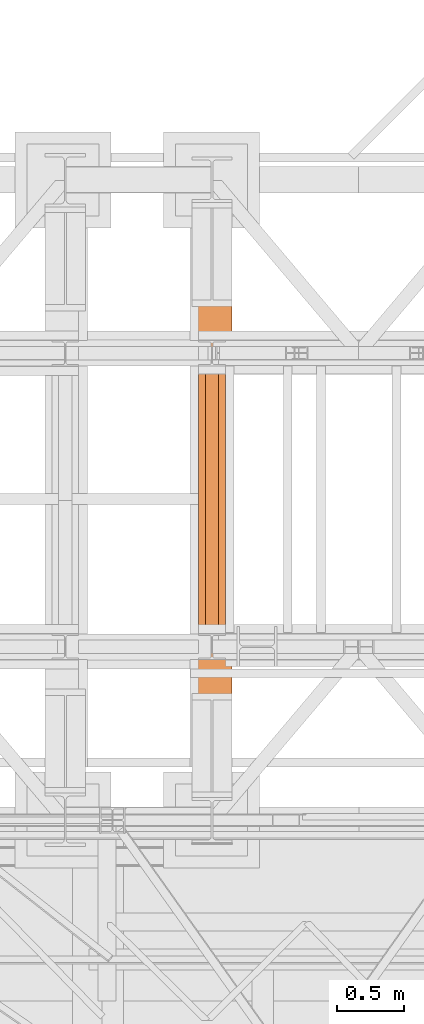
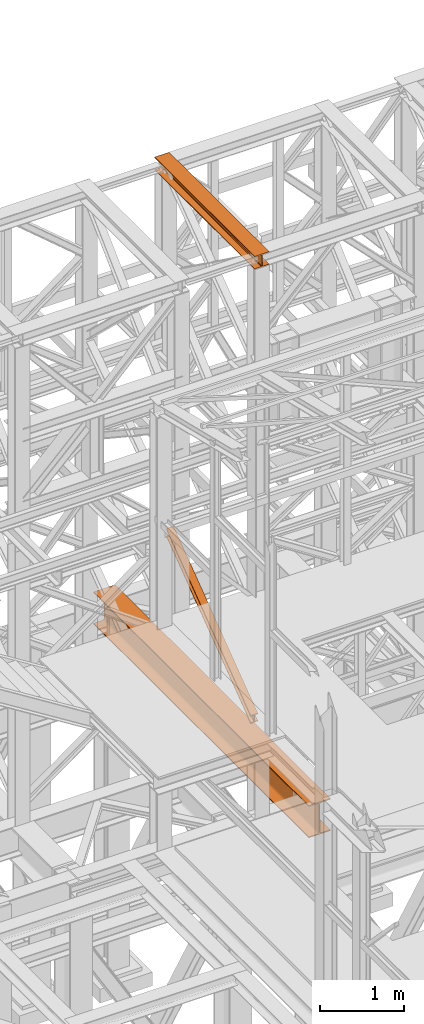
# One storey, part 124 of 208: 3 proxies.
"""IFC2X3 building model written with IfcOpenShell, lengths in millimetres."""

from ifc_helpers import new_model, entity, si_unit, converted_unit, frame, origin, origin_with_axes, place, context, subcontext, project, spatial, faceted_brep, element, save


model = new_model("IFC2X3")

# Units and contexts
model_context = context("Model", 3, precision=1e-05, world=origin())
plan_context = context("Plan", 3, precision=1e-05, world=origin())
body_context = subcontext(model_context, "Body", "Model", "MODEL_VIEW")
ifc_project = project(units=[si_unit("LENGTHUNIT", "METRE", prefix="MILLI"), converted_unit("PLANEANGLEUNIT", "DEGREE", entity("IfcPlaneAngleMeasure", 0.0174532925199433), si_unit("PLANEANGLEUNIT", "RADIAN"), dimensions=[0, 0, 0, 0, 0, 0, 0]), si_unit("AREAUNIT", "SQUARE_METRE"), si_unit("VOLUMEUNIT", "CUBIC_METRE")], contexts=[model_context, plan_context])

# Building, storey
building_placement = place(None, origin())
building = spatial("IfcBuilding", under=ifc_project, at=building_placement, CompositionType="COMPLEX")
storey_placement = place(building_placement, origin_with_axes())
storey = spatial("IfcBuildingStorey", under=building, at=storey_placement, Name="Geschoss", CompositionType="ELEMENT")

# Proxies
proxy_1_placement = place(storey_placement, frame((3143.254974489131, -17432.57439531566, 4812.990005364416), z_axis=(0.0, 0.0, 1.0), x_axis=(1.0, 0.0, 0.0)))
element("IfcBuildingElementProxy", 1, at=proxy_1_placement, inside=storey, context=body_context, shape_type="Brep", body=[
    faceted_brep([(300.0100000000002, 0.00999999999839929, 472.0100000000002), (300.0100000000002, 5140.010003576275, 472.0100000000002), (300.0100000000002, 5140.010003576275, 458.0100000000002), (300.0100000000002, 0.00999999999839929, 458.0100000000002), (300.0100000000002, 0.00999999999839929, 458.0100000000002), (300.0100000000002, 5140.010003576275, 458.0100000000002), (182.2600000000002, 5140.010003576275, 458.0100000000002), (182.2600000000002, 0.00999999999839929, 458.0100000000002), (182.2600000000002, 0.00999999999839929, 458.0100000000002), (182.2600000000002, 5140.010003576275, 458.0100000000002), (173.9165694541389, 5140.010003576275, 456.6884339422595), (173.9165694541389, 0.00999999999839929, 456.6884339422595), (173.9165694541389, 0.00999999999839929, 456.6884339422595), (173.9165694541389, 5140.010003576275, 456.6884339422595), (166.3898249342001, 5140.010003576275, 452.8534254634024), (166.3898249342001, 0.00999999999839929, 452.8534254634024), (166.3898249342001, 0.00999999999839929, 452.8534254634024), (166.3898249342001, 5140.010003576275, 452.8534254634024), (160.416574536599, 5140.010003576275, 446.8801750658013), (160.416574536599, 0.00999999999839929, 446.8801750658013), (160.416574536599, 0.00999999999839929, 446.8801750658013), (160.416574536599, 5140.010003576275, 446.8801750658013), (156.5815660577409, 5140.010003576275, 439.3534305458607), (156.5815660577409, 0.00999999999839929, 439.3534305458607), (156.5815660577409, 0.00999999999839929, 439.3534305458607), (156.5815660577409, 5140.010003576275, 439.3534305458607), (155.2600000000002, 5140.010003576275, 431.0100000000002), (155.2600000000002, 0.00999999999839929, 431.0100000000002), (155.2600000000002, 0.00999999999839929, 431.0100000000002), (155.2600000000002, 5140.010003576275, 431.0100000000002), (155.2600000000002, 5140.010003576275, 41.01000000000022), (155.2600000000002, 0.00999999999839929, 41.01000000000022), (155.2600000000002, 0.00999999999839929, 41.01000000000022), (155.2600000000002, 5140.010003576275, 41.01000000000022), (156.5815660577409, 5140.010003576275, 32.66656945413979), (156.5815660577409, 0.00999999999839929, 32.66656945413979), (156.5815660577409, 0.00999999999839929, 32.66656945413979), (156.5815660577409, 5140.010003576275, 32.66656945413979), (160.416574536599, 5140.010003576275, 25.13982493419826), (160.416574536599, 0.00999999999839929, 25.13982493419826), (160.416574536599, 0.00999999999839929, 25.13982493419826), (160.416574536599, 5140.010003576275, 25.13982493419826), (166.3898249342001, 5140.010003576275, 19.16657453659809), (166.3898249342001, 0.00999999999839929, 19.16657453659809), (166.3898249342001, 0.00999999999839929, 19.16657453659809), (166.3898249342001, 5140.010003576275, 19.16657453659809), (173.9165694541389, 5140.010003576275, 15.33156605774093), (173.9165694541389, 0.00999999999839929, 15.33156605774093), (173.9165694541389, 0.00999999999839929, 15.33156605774093), (173.9165694541389, 5140.010003576275, 15.33156605774093), (182.2600000000002, 5140.010003576275, 14.01000000000022), (182.2600000000002, 0.00999999999839929, 14.01000000000022), (182.2600000000002, 0.00999999999839929, 14.01000000000022), (182.2600000000002, 5140.010003576275, 14.01000000000022), (300.0100000000002, 5140.010003576275, 14.01000000000022), (300.0100000000002, 0.00999999999839929, 14.01000000000022), (300.0100000000002, 0.00999999999839929, 14.01000000000022), (300.0100000000002, 5140.010003576275, 14.01000000000022), (300.0100000000002, 5140.010003576275, 0.01000000000021828), (300.0100000000002, 0.00999999999839929, 0.01000000000021828), (300.0100000000002, 0.00999999999839929, 0.01000000000021828), (300.0100000000002, 5140.010003576275, 0.01000000000021828), (0.01000000000021828, 5140.010003576275, 0.01000000000021828), (0.01000000000021828, 0.00999999999839929, 0.01000000000021828), (0.01000000000021828, 0.00999999999839929, 0.01000000000021828), (0.01000000000021828, 5140.010003576275, 0.01000000000021828), (0.01000000000021828, 5140.010003576275, 14.01000000000022), (0.01000000000021828, 0.00999999999839929, 14.01000000000022), (0.01000000000021828, 0.00999999999839929, 14.01000000000022), (0.01000000000021828, 5140.010003576275, 14.01000000000022), (117.7600000000002, 5140.010003576275, 14.01000000000022), (117.7600000000002, 0.00999999999839929, 14.01000000000022), (117.7600000000002, 0.00999999999839929, 14.01000000000022), (117.7600000000002, 5140.010003576275, 14.01000000000022), (126.1034305458616, 5140.010003576275, 15.33156605774093), (126.1034305458616, 0.00999999999839929, 15.33156605774093), (126.1034305458616, 0.00999999999839929, 15.33156605774093), (126.1034305458616, 5140.010003576275, 15.33156605774093), (133.6301750658004, 5140.010003576275, 19.16657453659809), (133.6301750658004, 0.00999999999839929, 19.16657453659809), (133.6301750658004, 0.00999999999839929, 19.16657453659809), (133.6301750658004, 5140.010003576275, 19.16657453659809), (139.6034254634014, 5140.010003576275, 25.13982493419826), (139.6034254634014, 0.00999999999839929, 25.13982493419826), (139.6034254634014, 0.00999999999839929, 25.13982493419826), (139.6034254634014, 5140.010003576275, 25.13982493419826), (143.4384339422595, 5140.010003576275, 32.66656945413979), (143.4384339422595, 0.00999999999839929, 32.66656945413979), (143.4384339422595, 0.00999999999839929, 32.66656945413979), (143.4384339422595, 5140.010003576275, 32.66656945413979), (144.7600000000002, 5140.010003576275, 41.01000000000022), (144.7600000000002, 0.00999999999839929, 41.01000000000022), (144.7600000000002, 0.00999999999839929, 41.01000000000022), (144.7600000000002, 5140.010003576275, 41.01000000000022), (144.7600000000002, 5140.010003576275, 431.0100000000002), (144.7600000000002, 0.00999999999839929, 431.0100000000002), (144.7600000000002, 0.00999999999839929, 431.0100000000002), (144.7600000000002, 5140.010003576275, 431.0100000000002), (143.4384339422595, 5140.010003576275, 439.3534305458607), (143.4384339422595, 0.00999999999839929, 439.3534305458607), (143.4384339422595, 0.00999999999839929, 439.3534305458607), (143.4384339422595, 5140.010003576275, 439.3534305458607), (139.6034254634014, 5140.010003576275, 446.8801750658013), (139.6034254634014, 0.00999999999839929, 446.8801750658013), (139.6034254634014, 0.00999999999839929, 446.8801750658013), (139.6034254634014, 5140.010003576275, 446.8801750658013), (133.6301750658004, 5140.010003576275, 452.8534254634024), (133.6301750658004, 0.00999999999839929, 452.8534254634024), (133.6301750658004, 0.00999999999839929, 452.8534254634024), (133.6301750658004, 5140.010003576275, 452.8534254634024), (126.1034305458616, 5140.010003576275, 456.6884339422595), (126.1034305458616, 0.00999999999839929, 456.6884339422595), (126.1034305458616, 0.00999999999839929, 456.6884339422595), (126.1034305458616, 5140.010003576275, 456.6884339422595), (117.7600000000002, 5140.010003576275, 458.0100000000002), (117.7600000000002, 0.00999999999839929, 458.0100000000002), (117.7600000000002, 0.00999999999839929, 458.0100000000002), (117.7600000000002, 5140.010003576275, 458.0100000000002), (0.01000000000021828, 5140.010003576275, 458.0100000000002), (0.01000000000021828, 0.00999999999839929, 458.0100000000002), (0.01000000000021828, 0.00999999999839929, 458.0100000000002), (0.01000000000021828, 5140.010003576275, 458.0100000000002), (0.01000000000021828, 5140.010003576275, 472.0100000000002), (0.01000000000021828, 0.00999999999839929, 472.0100000000002), (0.01000000000021828, 0.00999999999839929, 472.0100000000002), (0.01000000000021828, 5140.010003576275, 472.0100000000002), (300.0100000000002, 5140.010003576275, 472.0100000000002), (300.0100000000002, 0.00999999999839929, 472.0100000000002), (300.0100000000002, 0.00999999999839929, 472.0100000000002), (300.0100000000002, 0.00999999999839929, 458.0100000000002), (182.2600000000002, 0.00999999999839929, 458.0100000000002), (173.9165694541389, 0.00999999999839929, 456.6884339422595), (166.3898249342001, 0.00999999999839929, 452.8534254634024), (160.416574536599, 0.00999999999839929, 446.8801750658013), (156.5815660577409, 0.00999999999839929, 439.3534305458607), (155.2600000000002, 0.00999999999839929, 431.0100000000002), (155.2600000000002, 0.00999999999839929, 41.01000000000022), (156.5815660577409, 0.00999999999839929, 32.66656945413979), (160.416574536599, 0.00999999999839929, 25.13982493419826), (166.3898249342001, 0.00999999999839929, 19.16657453659809), (173.9165694541389, 0.00999999999839929, 15.33156605774093), (182.2600000000002, 0.00999999999839929, 14.01000000000022), (300.0100000000002, 0.00999999999839929, 14.01000000000022), (300.0100000000002, 0.00999999999839929, 0.01000000000021828), (0.01000000000021828, 0.00999999999839929, 0.01000000000021828), (0.01000000000021828, 0.00999999999839929, 14.01000000000022), (117.7600000000002, 0.00999999999839929, 14.01000000000022), (126.1034305458616, 0.00999999999839929, 15.33156605774093), (133.6301750658004, 0.00999999999839929, 19.16657453659809), (139.6034254634014, 0.00999999999839929, 25.13982493419826), (143.4384339422595, 0.00999999999839929, 32.66656945413979), (144.7600000000002, 0.00999999999839929, 41.01000000000022), (144.7600000000002, 0.00999999999839929, 431.0100000000002), (143.4384339422595, 0.00999999999839929, 439.3534305458607), (139.6034254634014, 0.00999999999839929, 446.8801750658013), (133.6301750658004, 0.00999999999839929, 452.8534254634024), (126.1034305458616, 0.00999999999839929, 456.6884339422595), (117.7600000000002, 0.00999999999839929, 458.0100000000002), (0.01000000000021828, 0.00999999999839929, 458.0100000000002), (0.01000000000021828, 0.00999999999839929, 472.0100000000002), (300.0100000000002, 5140.010003576275, 472.0100000000002), (0.01000000000021828, 5140.010003576275, 472.0100000000002), (0.01000000000021828, 5140.010003576275, 458.0100000000002), (117.7600000000002, 5140.010003576275, 458.0100000000002), (126.1034305458616, 5140.010003576275, 456.6884339422595), (133.6301750658004, 5140.010003576275, 452.8534254634024), (139.6034254634014, 5140.010003576275, 446.8801750658013), (143.4384339422595, 5140.010003576275, 439.3534305458607), (144.7600000000002, 5140.010003576275, 431.0100000000002), (144.7600000000002, 5140.010003576275, 41.01000000000022), (143.4384339422595, 5140.010003576275, 32.66656945413979), (139.6034254634014, 5140.010003576275, 25.13982493419826), (133.6301750658004, 5140.010003576275, 19.16657453659809), (126.1034305458616, 5140.010003576275, 15.33156605774093), (117.7600000000002, 5140.010003576275, 14.01000000000022), (0.01000000000021828, 5140.010003576275, 14.01000000000022), (0.01000000000021828, 5140.010003576275, 0.01000000000021828), (300.0100000000002, 5140.010003576275, 0.01000000000021828), (300.0100000000002, 5140.010003576275, 14.01000000000022), (182.2600000000002, 5140.010003576275, 14.01000000000022), (173.9165694541389, 5140.010003576275, 15.33156605774093), (166.3898249342001, 5140.010003576275, 19.16657453659809), (160.416574536599, 5140.010003576275, 25.13982493419826), (156.5815660577409, 5140.010003576275, 32.66656945413979), (155.2600000000002, 5140.010003576275, 41.01000000000022), (155.2600000000002, 5140.010003576275, 431.0100000000002), (156.5815660577409, 5140.010003576275, 439.3534305458607), (160.416574536599, 5140.010003576275, 446.8801750658013), (166.3898249342001, 5140.010003576275, 452.8534254634024), (173.9165694541389, 5140.010003576275, 456.6884339422595), (182.2600000000002, 5140.010003576275, 458.0100000000002), (300.0100000000002, 5140.010003576275, 458.0100000000002)], [[[0, 1, 2, 3]], [[4, 5, 6, 7]], [[8, 9, 10, 11]], [[12, 13, 14, 15]], [[16, 17, 18, 19]], [[20, 21, 22, 23]], [[24, 25, 26, 27]], [[28, 29, 30, 31]], [[32, 33, 34, 35]], [[36, 37, 38, 39]], [[40, 41, 42, 43]], [[44, 45, 46, 47]], [[48, 49, 50, 51]], [[52, 53, 54, 55]], [[56, 57, 58, 59]], [[60, 61, 62, 63]], [[64, 65, 66, 67]], [[68, 69, 70, 71]], [[72, 73, 74, 75]], [[76, 77, 78, 79]], [[80, 81, 82, 83]], [[84, 85, 86, 87]], [[88, 89, 90, 91]], [[92, 93, 94, 95]], [[96, 97, 98, 99]], [[100, 101, 102, 103]], [[104, 105, 106, 107]], [[108, 109, 110, 111]], [[112, 113, 114, 115]], [[116, 117, 118, 119]], [[120, 121, 122, 123]], [[124, 125, 126, 127]], [[128, 129, 130, 131, 132, 133, 134, 135, 136, 137, 138, 139, 140, 141, 142, 143, 144, 145, 146, 147, 148, 149, 150, 151, 152, 153, 154, 155, 156, 157, 158, 159]], [[160, 161, 162, 163, 164, 165, 166, 167, 168, 169, 170, 171, 172, 173, 174, 175, 176, 177, 178, 179, 180, 181, 182, 183, 184, 185, 186, 187, 188, 189, 190, 191]]], orient=[[False], [False], [False], [False], [False], [False], [False], [False], [False], [False], [False], [False], [False], [False], [False], [False], [False], [False], [False], [False], [False], [False], [False], [False], [False], [False], [False], [False], [False], [False], [False], [False], [False], [False]]),
])
proxy_2_placement = place(storey_placement, frame((3193.25496703855, -16057.57439657638, 12249.99005869381), z_axis=(0.0, 0.0, 1.0), x_axis=(1.0, 0.0, 0.0)))
element("IfcBuildingElementProxy", 2, at=proxy_2_placement, inside=storey, context=body_context, shape_type="Brep", body=[
    faceted_brep([(0.01000000000021828, 2390.010012516977, 0.01000000000021828), (200.0100029802325, 2390.010012516977, 0.01000000000021828), (200.0100029802325, 2390.010012516977, 10.00999791383765), (121.2600035762789, 2390.010012516977, 10.01000536441825), (111.9441915473344, 2390.010012516977, 11.87455041170142), (105.1245498640838, 2390.010012516977, 18.69419349193595), (103.2600015571716, 2390.010012516977, 28.01000458955787), (103.2600015571716, 2390.010012516977, 162.0100153779986), (105.1245498640838, 2390.010012516977, 171.3258264756205), (111.9441915473344, 2390.010012516977, 178.145469555855), (121.2600035762789, 2390.010012516977, 180.0100146031382), (200.0100029802325, 2390.010012516977, 180.0100146031382), (200.0100029802325, 2390.010012516977, 190.0100125169756), (0.01000000000021828, 2390.010012516977, 190.0100125169756), (0.01000000000021828, 2390.010012516977, 180.0100146031382), (78.75999940395377, 2390.010012516977, 180.0100146031382), (88.07581143289826, 2390.010012516977, 178.145469555855), (94.89545311614893, 2390.010012516977, 171.3258264756205), (96.76000142306111, 2390.010012516977, 162.0100153779986), (96.76000142306111, 2390.010012516977, 28.01000458955787), (94.89545311614893, 2390.010012516977, 18.69419349193595), (88.07581143289826, 2390.010012516977, 11.87455041170142), (78.75999940395377, 2390.010012516977, 10.01000536441825), (0.01000000000021828, 2390.010012516977, 10.00999791383765), (200.0100029802325, 2390.010012516977, 0.01000000000021828), (0.01000000000021828, 2390.010012516977, 0.01000000000021828), (0.01000000000021828, 0.01000000000021828, 0.01000000000021828), (200.0100029802325, 0.01000000000021828, 0.01000000000021828), (200.0100029802325, 2390.010012516977, 10.00999791383765), (200.0100029802325, 2390.010012516977, 0.01000000000021828), (200.0100029802325, 0.01000000000021828, 0.01000000000021828), (200.0100029802325, 0.01000000000021828, 10.00999791383765), (121.2600035762789, 2390.010012516977, 10.01000536441825), (200.0100029802325, 2390.010012516977, 10.00999791383765), (200.0100029802325, 0.01000000000021828, 10.00999791383765), (121.2600035762789, 0.01000000000021828, 10.01000536441825), (111.9441915473344, 2390.010012516977, 11.87455041170142), (121.2600035762789, 2390.010012516977, 10.01000536441825), (121.2600035762789, 0.01000000000021828, 10.01000536441825), (111.9441915473344, 0.01000000000021828, 11.87455041170142), (105.1245498640838, 2390.010012516977, 18.69419349193595), (111.9441915473344, 2390.010012516977, 11.87455041170142), (111.9441915473344, 0.01000000000021828, 11.87455041170142), (105.1245498640838, 0.01000000000021828, 18.69419349193595), (103.2600015571716, 2390.010012516977, 28.01000458955787), (105.1245498640838, 2390.010012516977, 18.69419349193595), (105.1245498640838, 0.01000000000021828, 18.69419349193595), (103.2600015571716, 0.01000000000021828, 28.01000458955787), (103.2600015571716, 2390.010012516977, 162.0100153779986), (103.2600015571716, 2390.010012516977, 28.01000458955787), (103.2600015571716, 0.01000000000021828, 28.01000458955787), (103.2600015571716, 0.01000000000021828, 162.0100153779986), (105.1245498640838, 2390.010012516977, 171.3258264756205), (103.2600015571716, 2390.010012516977, 162.0100153779986), (103.2600015571716, 0.01000000000021828, 162.0100153779986), (105.1245498640838, 0.01000000000021828, 171.3258264756205), (111.9441915473344, 2390.010012516977, 178.145469555855), (105.1245498640838, 2390.010012516977, 171.3258264756205), (105.1245498640838, 0.01000000000021828, 171.3258264756205), (111.9441915473344, 0.01000000000021828, 178.145469555855), (121.2600035762789, 2390.010012516977, 180.0100146031382), (111.9441915473344, 2390.010012516977, 178.145469555855), (111.9441915473344, 0.01000000000021828, 178.145469555855), (121.2600035762789, 0.01000000000021828, 180.0100146031382), (200.0100029802325, 2390.010012516977, 180.0100146031382), (121.2600035762789, 2390.010012516977, 180.0100146031382), (121.2600035762789, 0.01000000000021828, 180.0100146031382), (200.0100029802325, 0.01000000000021828, 180.0100146031382), (200.0100029802325, 2390.010012516977, 190.0100125169756), (200.0100029802325, 2390.010012516977, 180.0100146031382), (200.0100029802325, 0.01000000000021828, 180.0100146031382), (200.0100029802325, 0.01000000000021828, 190.0100125169756), (0.01000000000021828, 2390.010012516977, 190.0100125169756), (200.0100029802325, 2390.010012516977, 190.0100125169756), (200.0100029802325, 0.01000000000021828, 190.0100125169756), (0.01000000000021828, 0.01000000000021828, 190.0100125169756), (0.01000000000021828, 2390.010012516977, 180.0100146031382), (0.01000000000021828, 2390.010012516977, 190.0100125169756), (0.01000000000021828, 0.01000000000021828, 190.0100125169756), (0.01000000000021828, 0.01000000000021828, 180.0100146031382), (78.75999940395377, 2390.010012516977, 180.0100146031382), (0.01000000000021828, 2390.010012516977, 180.0100146031382), (0.01000000000021828, 0.01000000000021828, 180.0100146031382), (78.75999940395377, 0.01000000000021828, 180.0100146031382), (88.07581143289826, 2390.010012516977, 178.145469555855), (78.75999940395377, 2390.010012516977, 180.0100146031382), (78.75999940395377, 0.01000000000021828, 180.0100146031382), (88.07581143289826, 0.01000000000021828, 178.145469555855), (94.89545311614893, 2390.010012516977, 171.3258264756205), (88.07581143289826, 2390.010012516977, 178.145469555855), (88.07581143289826, 0.01000000000021828, 178.145469555855), (94.89545311614893, 0.01000000000021828, 171.3258264756205), (96.76000142306111, 2390.010012516977, 162.0100153779986), (94.89545311614893, 2390.010012516977, 171.3258264756205), (94.89545311614893, 0.01000000000021828, 171.3258264756205), (96.76000142306111, 0.01000000000021828, 162.0100153779986), (96.76000142306111, 2390.010012516977, 28.01000458955787), (96.76000142306111, 2390.010012516977, 162.0100153779986), (96.76000142306111, 0.01000000000021828, 162.0100153779986), (96.76000142306111, 0.01000000000021828, 28.01000458955787), (94.89545311614893, 2390.010012516977, 18.69419349193595), (96.76000142306111, 2390.010012516977, 28.01000458955787), (96.76000142306111, 0.01000000000021828, 28.01000458955787), (94.89545311614893, 0.01000000000021828, 18.69419349193595), (88.07581143289826, 2390.010012516977, 11.87455041170142), (94.89545311614893, 2390.010012516977, 18.69419349193595), (94.89545311614893, 0.01000000000021828, 18.69419349193595), (88.07581143289826, 0.01000000000021828, 11.87455041170142), (78.75999940395377, 2390.010012516977, 10.01000536441825), (88.07581143289826, 2390.010012516977, 11.87455041170142), (88.07581143289826, 0.01000000000021828, 11.87455041170142), (78.75999940395377, 0.01000000000021828, 10.01000536441825), (0.01000000000021828, 2390.010012516977, 10.00999791383765), (78.75999940395377, 2390.010012516977, 10.01000536441825), (78.75999940395377, 0.01000000000021828, 10.01000536441825), (0.01000000000021828, 0.01000000000021828, 10.00999791383765), (0.01000000000021828, 2390.010012516977, 0.01000000000021828), (0.01000000000021828, 2390.010012516977, 10.00999791383765), (0.01000000000021828, 0.01000000000021828, 10.00999791383765), (0.01000000000021828, 0.01000000000021828, 0.01000000000021828), (0.01000000000021828, 0.01000000000021828, 0.01000000000021828), (0.01000000000021828, 0.01000000000021828, 10.00999791383765), (78.75999940395377, 0.01000000000021828, 10.01000536441825), (88.07581143289826, 0.01000000000021828, 11.87455041170142), (94.89545311614893, 0.01000000000021828, 18.69419349193595), (96.76000142306111, 0.01000000000021828, 28.01000458955787), (96.76000142306111, 0.01000000000021828, 162.0100153779986), (94.89545311614893, 0.01000000000021828, 171.3258264756205), (88.07581143289826, 0.01000000000021828, 178.145469555855), (78.75999940395377, 0.01000000000021828, 180.0100146031382), (0.01000000000021828, 0.01000000000021828, 180.0100146031382), (0.01000000000021828, 0.01000000000021828, 190.0100125169756), (200.0100029802325, 0.01000000000021828, 190.0100125169756), (200.0100029802325, 0.01000000000021828, 180.0100146031382), (121.2600035762789, 0.01000000000021828, 180.0100146031382), (111.9441915473344, 0.01000000000021828, 178.145469555855), (105.1245498640838, 0.01000000000021828, 171.3258264756205), (103.2600015571716, 0.01000000000021828, 162.0100153779986), (103.2600015571716, 0.01000000000021828, 28.01000458955787), (105.1245498640838, 0.01000000000021828, 18.69419349193595), (111.9441915473344, 0.01000000000021828, 11.87455041170142), (121.2600035762789, 0.01000000000021828, 10.01000536441825), (200.0100029802325, 0.01000000000021828, 10.00999791383765), (200.0100029802325, 0.01000000000021828, 0.01000000000021828)], [[[0, 1, 2, 3, 4, 5, 6, 7, 8, 9, 10, 11, 12, 13, 14, 15, 16, 17, 18, 19, 20, 21, 22, 23]], [[24, 25, 26, 27]], [[28, 29, 30, 31]], [[32, 33, 34, 35]], [[36, 37, 38, 39]], [[40, 41, 42, 43]], [[44, 45, 46, 47]], [[48, 49, 50, 51]], [[52, 53, 54, 55]], [[56, 57, 58, 59]], [[60, 61, 62, 63]], [[64, 65, 66, 67]], [[68, 69, 70, 71]], [[72, 73, 74, 75]], [[76, 77, 78, 79]], [[80, 81, 82, 83]], [[84, 85, 86, 87]], [[88, 89, 90, 91]], [[92, 93, 94, 95]], [[96, 97, 98, 99]], [[100, 101, 102, 103]], [[104, 105, 106, 107]], [[108, 109, 110, 111]], [[112, 113, 114, 115]], [[116, 117, 118, 119]], [[120, 121, 122, 123, 124, 125, 126, 127, 128, 129, 130, 131, 132, 133, 134, 135, 136, 137, 138, 139, 140, 141, 142, 143]]], orient=[[False], [False], [False], [False], [False], [False], [False], [False], [False], [False], [False], [False], [False], [False], [False], [False], [False], [False], [False], [False], [False], [False], [False], [False], [False], [False]]),
])
proxy_3_placement = place(storey_placement, frame((3243.082798491103, -15873.1965123697, 5499.689768811883), z_axis=(0.0, 0.0, 1.0), x_axis=(1.0, 0.0, 0.0)))
element("IfcBuildingElementProxy", 3, at=proxy_3_placement, inside=storey, context=body_context, shape_type="Brep", body=[
    faceted_brep([(100.0229428112289, 2015.632115793322, 1505.703241650141), (100.1858455764686, 1.953628280809426, 0.02100513656296243), (100.1847800613887, 1.791659257409265, 9.702984703128095), (100.0218641931642, 2015.632115793322, 1515.50632986583), (0.02294341679771605, 2015.632115793322, 1505.692236513578), (0.1858461820338562, 1.953628280809426, 0.01000000000021828), (100.1858455764686, 1.953628280809426, 0.02100513656296243), (100.0229428112289, 2015.632115793322, 1505.703241650141), (0.02186479873125791, 2015.632115793322, 1515.495324729271), (0.1847806669538841, 1.791659257407446, 9.691979566568989), (0.1858461820338562, 1.953628280809426, 0.01000000000021828), (0.02294341679771605, 2015.632115793322, 1505.692236513578), (47.52186451108355, 2015.632115793322, 1515.500552169136), (47.68478037930981, 1.791659257407446, 9.697207006434837), (0.1847806669538841, 1.791659257407446, 9.691979566568989), (0.02186479873125791, 2015.632115793322, 1515.495324729271), (47.51107833042624, 2015.632115793322, 1613.531434326045), (47.67412522851737, 0.1719690234003792, 106.517002672068), (47.68478037930981, 1.791659257407446, 9.697207006434837), (47.52186451108355, 2015.632115793322, 1515.500552169136), (0.01107861806849542, 2015.632115793322, 1613.526206886179), (0.174125516157801, 0.1719690234003792, 106.5117752322021), (47.67412522851737, 0.1719690234003792, 106.517002672068), (47.51107833042624, 2015.632115793322, 1613.531434326045), (0.01000000000021828, 2015.632115793322, 1623.329295101868), (0.1730600010778289, 0.01000000000021828, 116.1937547987636), (0.174125516157801, 0.1719690234003792, 106.5117752322021), (0.01107861806849542, 2015.632115793322, 1613.526206886179), (100.0099993944386, 2015.632115793322, 1623.340300238435), (100.1730593955126, 0.01000000000203727, 116.2047599353264), (0.1730600010778289, 0.01000000000021828, 116.1937547987636), (0.01000000000021828, 2015.632115793322, 1623.329295101868), (100.0110780125051, 2015.632115793322, 1613.537212022739), (100.1741249105908, 0.1719690234003792, 106.5227803687612), (100.1730593955126, 0.01000000000203727, 116.2047599353264), (100.0099993944386, 2015.632115793322, 1623.340300238435), (52.51107830014917, 2015.632115793322, 1613.531984582873), (52.67412519823665, 0.1719690234003792, 106.5175529288954), (100.1741249105908, 0.1719690234003792, 106.5227803687612), (100.0110780125051, 2015.632115793322, 1613.537212022739), (52.52186448080829, 2015.632115793322, 1515.501102425964), (52.68478034903274, 1.791659257409265, 9.697757263262247), (52.67412519823665, 0.1719690234003792, 106.5175529288954), (52.51107830014917, 2015.632115793322, 1613.531984582873), (100.0218641931642, 2015.632115793322, 1515.50632986583), (100.1847800613887, 1.791659257409265, 9.702984703128095), (52.68478034903274, 1.791659257409265, 9.697757263262247), (52.52186448080829, 2015.632115793322, 1515.501102425964), (100.1858455764686, 1.953628280809426, 0.02100513656296243), (0.1858461820338562, 1.953628280809426, 0.01000000000021828), (0.1847806669538841, 1.791659257407446, 9.691979566568989), (47.68478037930981, 1.791659257407446, 9.697207006434837), (47.67412522851737, 0.1719690234003792, 106.517002672068), (0.174125516157801, 0.1719690234003792, 106.5117752322021), (0.1730600010778289, 0.01000000000021828, 116.1937547987636), (100.1730593955126, 0.01000000000203727, 116.2047599353264), (100.1741249105908, 0.1719690234003792, 106.5227803687612), (52.67412519823665, 0.1719690234003792, 106.5175529288954), (52.68478034903274, 1.791659257409265, 9.697757263262247), (100.1847800613887, 1.791659257409265, 9.702984703128095), (100.0218641931642, 2015.632115793322, 1515.50632986583), (52.52186448080829, 2015.632115793322, 1515.501102425964), (52.51107830014917, 2015.632115793322, 1613.531984582873), (100.0110780125051, 2015.632115793322, 1613.537212022739), (100.0099993944386, 2015.632115793322, 1623.340300238435), (0.01000000000021828, 2015.632115793322, 1623.329295101868), (0.01107861806849542, 2015.632115793322, 1613.526206886179), (47.51107833042624, 2015.632115793322, 1613.531434326045), (47.52186451108355, 2015.632115793322, 1515.500552169136), (0.02186479873125791, 2015.632115793322, 1515.495324729271), (0.02294341679771605, 2015.632115793322, 1505.692236513578), (100.0229428112289, 2015.632115793322, 1505.703241650141)], [[[0, 1, 2, 3]], [[4, 5, 6, 7]], [[8, 9, 10, 11]], [[12, 13, 14, 15]], [[16, 17, 18, 19]], [[20, 21, 22, 23]], [[24, 25, 26, 27]], [[28, 29, 30, 31]], [[32, 33, 34, 35]], [[36, 37, 38, 39]], [[40, 41, 42, 43]], [[44, 45, 46, 47]], [[48, 49, 50, 51, 52, 53, 54, 55, 56, 57, 58, 59]], [[60, 61, 62, 63, 64, 65, 66, 67, 68, 69, 70, 71]]], orient=[[False], [False], [False], [False], [False], [False], [False], [False], [False], [False], [False], [False], [False], [False]]),
])

save(model, "model.ifc")
